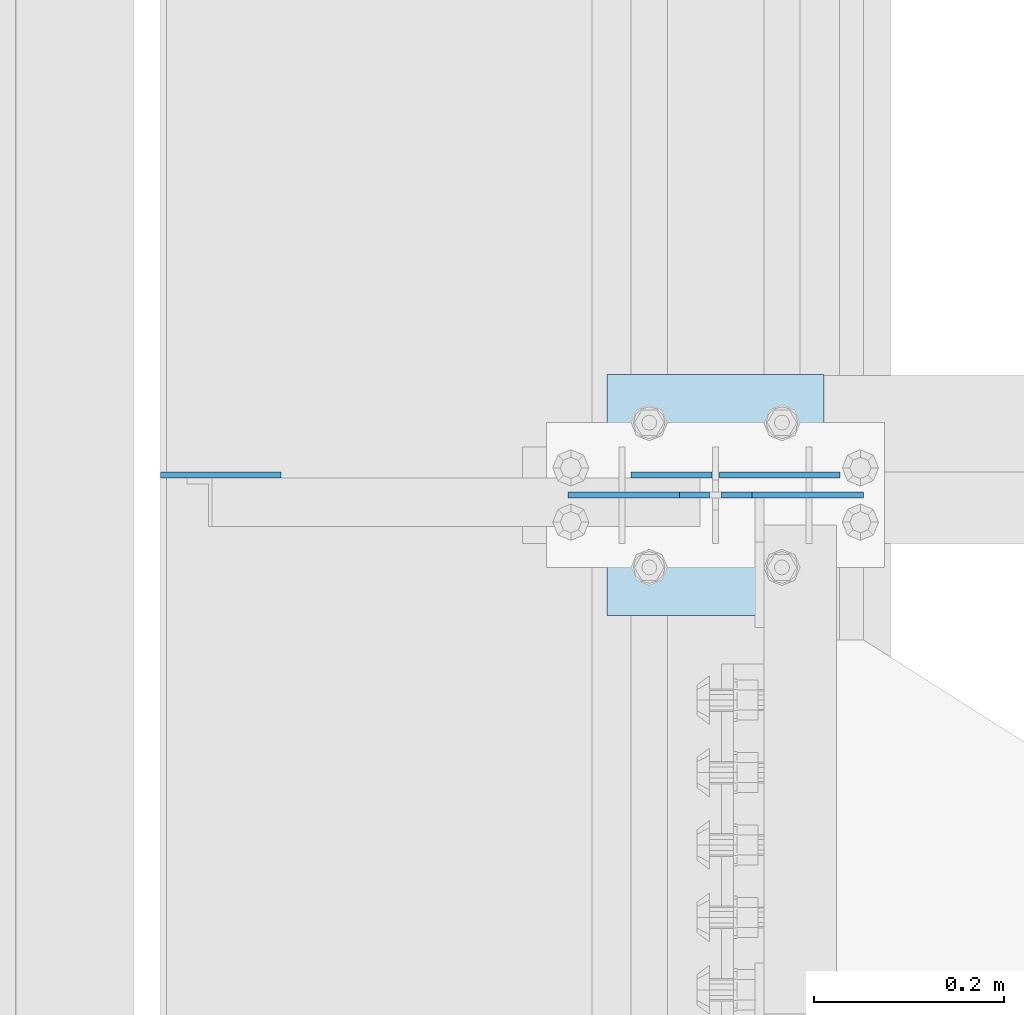
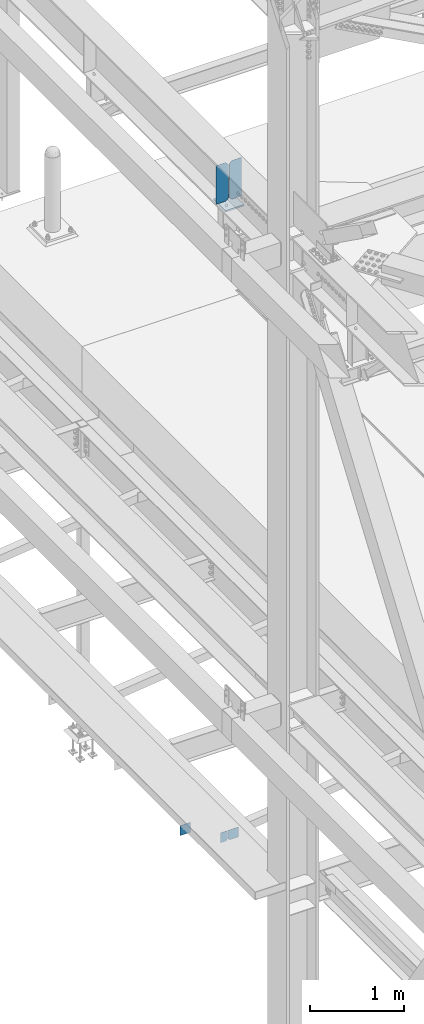
# One storey, part 3366 of 3843: 6 plates, 3 elements without a shape of their own.
"""IFC2X3 building model written with IfcOpenShell, lengths in millimetres."""

from ifc_helpers import new_model, si_unit, frame, origin_with_axes, place, context, subcontext, project, spatial, faceted_brep, material, type_object, element, aggregate, save


model = new_model("IFC2X3")

# Units and contexts
model_context = context("Model", 3, precision=1e-05, world=origin_with_axes())
body_context = subcontext(model_context, "Body", "Model", "MODEL_VIEW")
ifc_project = project(units=[si_unit("LENGTHUNIT", "METRE", prefix="MILLI"), si_unit("AREAUNIT", "SQUARE_METRE"), si_unit("VOLUMEUNIT", "CUBIC_METRE"), si_unit("MASSUNIT", "GRAM", prefix="KILO"), si_unit("TIMEUNIT", "SECOND"), si_unit("PLANEANGLEUNIT", "RADIAN"), si_unit("SOLIDANGLEUNIT", "STERADIAN"), si_unit("THERMODYNAMICTEMPERATUREUNIT", "DEGREE_CELSIUS"), si_unit("LUMINOUSINTENSITYUNIT", "LUMEN")], contexts=[model_context])

# Site, building, storey
site_placement = place(None, origin_with_axes())
site = spatial("IfcSite", under=ifc_project, at=site_placement, CompositionType="ELEMENT")
building_placement = place(site_placement, origin_with_axes())
building = spatial("IfcBuilding", under=site, at=building_placement, Name="Undefined", CompositionType="ELEMENT")
storey_placement = place(building_placement, origin_with_axes())
storey = spatial("IfcBuildingStorey", under=building, at=storey_placement, Name="Undefined", CompositionType="ELEMENT", Elevation=0.0)

# Assembly, plates
assembly_1_placement = place(storey_placement, origin_with_axes())
assembly_1 = element("IfcElementAssembly", 1, at=assembly_1_placement, inside=storey, Name="BEAM", AssemblyPlace="NOTDEFINED", PredefinedType="RIGID_FRAME")
ifc_material = material(Name="STEEL/A572-50")
plate_type_1 = type_object("IfcPlateType", PredefinedType="NOTDEFINED")
plate_1_placement = place(assembly_1_placement, frame((36579.96875, 77021.233594, 33769.3), z_axis=(0.0, 0.0, -1.0), x_axis=(1.0, 0.0, 0.0)))
plate_1 = element("IfcPlate", 2, at=plate_1_placement, type_object=plate_type_1, material=ifc_material, Name="PLATE", context=body_context, shape_type="Brep", body=[
    faceted_brep([(0.0, -3.17499999999927, 0.0), (0.0, -3.17500000000291, 107.950000000004), (0.0, 3.17500000000291, 107.950000000004), (0.0, 3.17499999999927, 0.0), (19.0500000000029, -3.17500000000291, 127.0), (19.0500000000029, 3.17500000000291, 127.0), (127.0, -3.17500000000291, 127.0), (127.0, 3.17500000000291, 127.0), (127.0, -3.17500000000291, 0.0), (127.0, 3.17500000000291, 0.0)], [[[0, 1, 2, 3]], [[1, 4, 5, 2]], [[4, 6, 7, 5]], [[6, 8, 9, 7]], [[8, 0, 3, 9]], [[5, 7, 9, 3, 2]], [[8, 6, 4, 1, 0]]]),
])
plate_2_placement = place(assembly_1_placement, frame((35991.8000305176, 77021.2335940001, 33909.0000061035), z_axis=(0.0, 0.0, 1.0), x_axis=(1.0, 0.0, 0.0)))
plate_2 = element("IfcPlate", 3, at=plate_2_placement, type_object=plate_type_1, material=ifc_material, Name="PLATE", context=body_context, shape_type="Brep", body=[
    faceted_brep([(0.0, -3.17499999999927, 0.0), (-6.10351708019152e-06, -3.17500000000291, 126.999993896483), (-6.10351708019152e-06, 3.17500000000291, 126.999993896483), (0.0, 3.17499999999927, 0.0), (127.0, -3.17500000000291, 127.0), (127.0, 3.17500000000291, 127.0), (127.0, -3.17500000000291, 0.0), (127.0, 3.17500000000291, 0.0)], [[[0, 1, 2, 3]], [[1, 4, 5, 2]], [[4, 6, 7, 5]], [[6, 0, 3, 7]], [[5, 7, 3, 2]], [[6, 4, 1, 0]]]),
])
plate_type_2 = type_object("IfcPlateType", PredefinedType="NOTDEFINED")
plate_3_placement = place(assembly_1_placement, frame((36572.0312591215, 77021.233594, 33769.3), z_axis=(0.0, 0.0, -1.0), x_axis=(-1.0, 0.0, 0.0)))
plate_3 = element("IfcPlate", 4, at=plate_3_placement, type_object=plate_type_2, material=ifc_material, Name="PLATE", context=body_context, shape_type="Brep", body=[
    faceted_brep([(0.0, -3.17499999999927, 0.0), (0.0, -3.17500000000291, 107.950000000004), (0.0, 3.17500000000291, 107.950000000004), (0.0, 3.17499999999927, 0.0), (19.0500000000029, -3.17500000000291, 127.0), (19.0500000000029, 3.17500000000291, 127.0), (84.9312591264534, -3.17500000000291, 126.999993896701), (84.9312591264534, 3.17500000000291, 126.999993896701), (84.9312500000015, -3.17500000000291, 2.18278728425503e-10), (84.9312500000015, 3.17500000000291, 2.18278728425503e-10)], [[[0, 1, 2, 3]], [[1, 4, 5, 2]], [[4, 6, 7, 5]], [[6, 8, 9, 7]], [[8, 0, 3, 9]], [[5, 7, 9, 3, 2]], [[8, 6, 4, 1, 0]]]),
])
aggregate(assembly_1, [plate_1, plate_3, plate_2])

assembly_2_placement = place(storey_placement, origin_with_axes())
assembly_2 = element("IfcElementAssembly", 5, at=assembly_2_placement, inside=storey, Name="BEAM", AssemblyPlace="NOTDEFINED", PredefinedType="RIGID_FRAME")
plate_type_3 = type_object("IfcPlateType", PredefinedType="NOTDEFINED")
plate_4_placement = place(assembly_2_placement, frame((36731.575, 77000.1, 42446.575), z_axis=(0.0, 0.0, -1.0), x_axis=(-1.0, 0.0, 0.0)))
plate_4 = element("IfcPlate", 6, at=plate_4_placement, type_object=plate_type_3, material=ifc_material, Name="PLATE", context=body_context, shape_type="Brep", body=[
    faceted_brep([(0.0, -3.17499999999927, 0.0), (0.0, -3.17500000000291, 498.475000000006), (0.0, 3.17500000000291, 498.475000000006), (0.0, 3.17499999999927, 0.0), (117.475000000006, -3.17500000000291, 498.475000000006), (117.475000000006, 3.17500000000291, 498.475000000006), (149.225000000006, -3.17500000000291, 466.725000000006), (149.225000000006, 3.17500000000291, 466.725000000006), (149.225000000006, -3.17500000000291, 31.75), (149.225000000006, 3.17500000000291, 31.75), (117.475000000006, -3.17500000000291, 0.0), (117.475000000006, 3.17500000000291, 0.0)], [[[0, 1, 2, 3]], [[1, 4, 5, 2]], [[4, 6, 7, 5]], [[6, 8, 9, 7]], [[8, 10, 11, 9]], [[10, 0, 3, 11]], [[5, 7, 9, 11, 3, 2]], [[10, 8, 6, 4, 1, 0]]]),
])
plate_5_placement = place(assembly_2_placement, frame((36420.425, 77000.1, 42446.575), z_axis=(0.0, 0.0, -1.0), x_axis=(1.0, 0.0, 0.0)))
plate_5 = element("IfcPlate", 7, at=plate_5_placement, type_object=plate_type_3, material=ifc_material, Name="PLATE", context=body_context, shape_type="Brep", body=[
    faceted_brep([(0.0, -3.17499999999927, 0.0), (0.0, -3.17500000000291, 498.475000000006), (0.0, 3.17500000000291, 498.475000000006), (0.0, 3.17499999999927, 0.0), (117.475000000006, -3.17500000000291, 498.475000000006), (117.475000000006, 3.17500000000291, 498.475000000006), (149.225000000006, -3.17500000000291, 466.725000000006), (149.225000000006, 3.17500000000291, 466.725000000006), (149.225000000006, -3.17500000000291, 31.75), (149.225000000006, 3.17500000000291, 31.75), (117.475000000006, -3.17500000000291, 0.0), (117.475000000006, 3.17500000000291, 0.0)], [[[0, 1, 2, 3]], [[1, 4, 5, 2]], [[4, 6, 7, 5]], [[6, 8, 9, 7]], [[8, 10, 11, 9]], [[10, 0, 3, 11]], [[5, 7, 9, 11, 3, 2]], [[10, 8, 6, 4, 1, 0]]]),
])
aggregate(assembly_2, [plate_4, plate_5])

# Assembly, plate
assembly_3_placement = place(storey_placement, origin_with_axes())
assembly_3 = element("IfcElementAssembly", 8, at=assembly_3_placement, inside=storey, Name="POST", AssemblyPlace="NOTDEFINED", PredefinedType="RIGID_FRAME")
plate_type_4 = type_object("IfcPlateType", PredefinedType="NOTDEFINED")
plate_6_placement = place(assembly_3_placement, frame((36461.7000005181, 77127.1, 41916.35), z_axis=(0.0, -1.0, 0.0), x_axis=(1.0, 0.0, 0.0)))
plate_6 = element("IfcPlate", 9, at=plate_6_placement, type_object=plate_type_4, material=ifc_material, Name="PLATE", context=body_context, shape_type="Brep", body=[
    faceted_brep([(0.0, -9.52500000000146, 0.0), (0.0, -9.52500000000146, 254.0), (0.0, 9.52500000000146, 254.0), (0.0, 9.52500000000146, 0.0), (228.599999999999, -9.52500000000146, 254.0), (228.599999999999, 9.52500000000146, 254.0), (228.599999999999, -9.52500000000146, 0.0), (228.599999999999, 9.52500000000146, 0.0)], [[[0, 1, 2, 3]], [[1, 4, 5, 2]], [[4, 6, 7, 5]], [[6, 0, 3, 7]], [[5, 7, 3, 2]], [[6, 4, 1, 0]]]),
])
aggregate(assembly_3, [plate_6])

save(model, "model.ifc")
